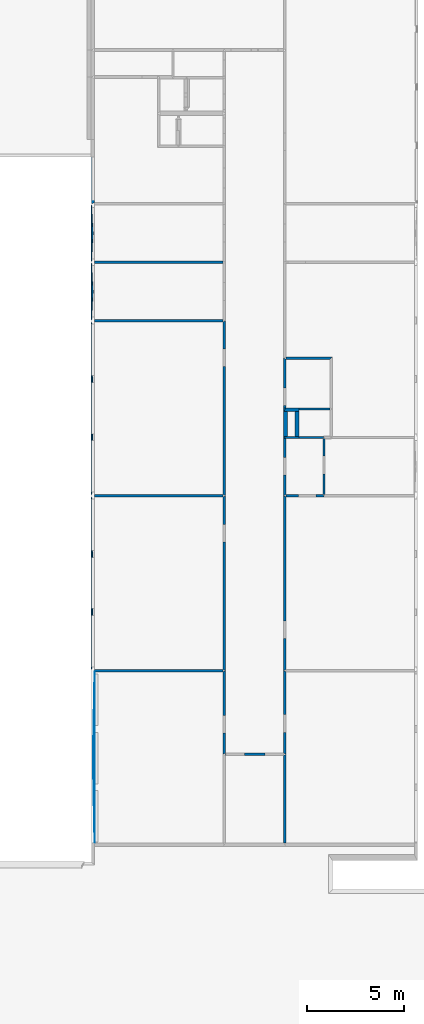
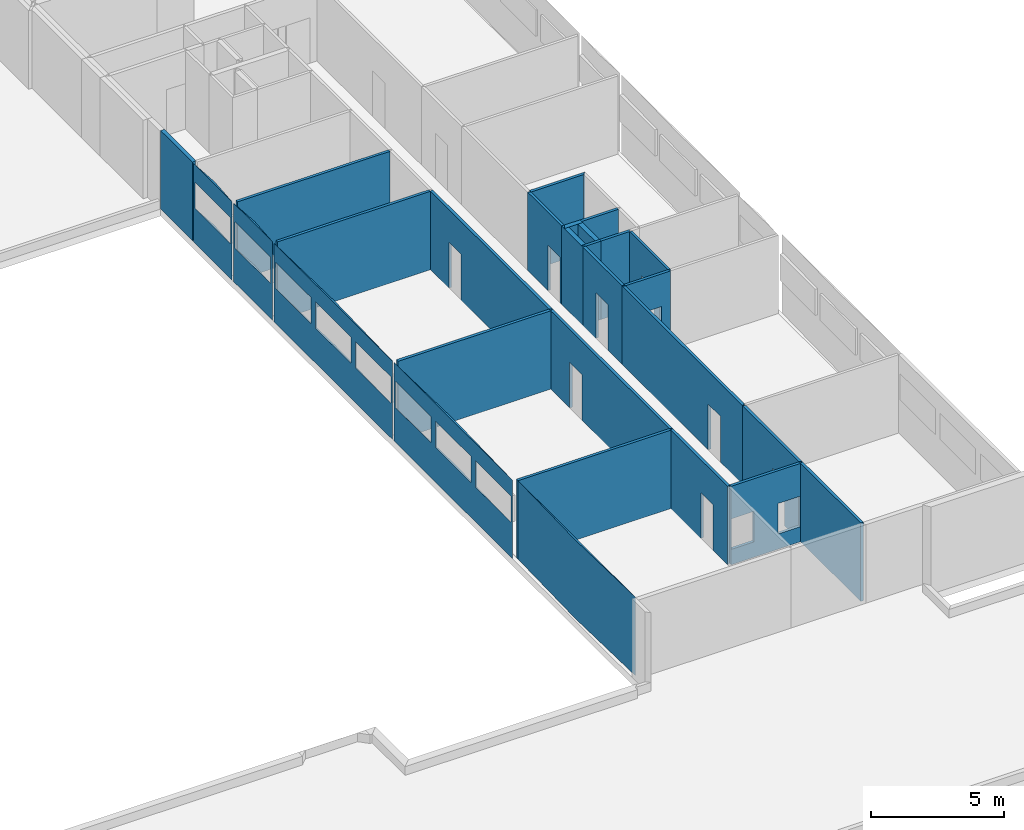
# One storey, part 2 of 72: 28 walls, 23 openings.
"""IFC2X3 building model written with IfcOpenShell, lengths in metres."""

from ifc_helpers import new_model, entity, si_unit, converted_unit, derived_unit, frame, origin_with_axes, place, context, project, spatial, polyline, outline, extrude, material, layer, layer_set, layer_usage, element, save


model = new_model("IFC2X3")

# Units and contexts
context_of_model_1 = context(None, 3, world=origin_with_axes())
context_of_model_2 = context(None, 3, world=origin_with_axes())
context_of_model_3 = context(None, 2, world=origin_with_axes())
context_of_model_4 = context(None, 3, world=origin_with_axes())
ifc_project = project(units=[si_unit("LENGTHUNIT", "METRE"), si_unit("AREAUNIT", "SQUARE_METRE"), si_unit("ELECTRICCURRENTUNIT", "AMPERE"), si_unit("ELECTRICVOLTAGEUNIT", "VOLT"), si_unit("ELECTRICRESISTANCEUNIT", "OHM"), si_unit("POWERUNIT", "WATT"), si_unit("MASSUNIT", "GRAM"), si_unit("SOLIDANGLEUNIT", "STERADIAN"), si_unit("THERMODYNAMICTEMPERATUREUNIT", "KELVIN"), si_unit("PRESSUREUNIT", "PASCAL"), si_unit("LUMINOUSFLUXUNIT", "LUMEN"), si_unit("ILLUMINANCEUNIT", "LUX"), si_unit("FREQUENCYUNIT", "HERTZ"), si_unit("VOLUMEUNIT", "CUBIC_METRE"), si_unit("TIMEUNIT", "SECOND"), derived_unit("VOLUMETRICFLOWRATEUNIT", [(si_unit("TIMEUNIT", "SECOND"), -1), (si_unit("VOLUMEUNIT", "CUBIC_METRE"), 1)]), derived_unit("THERMALTRANSMITTANCEUNIT", [(si_unit("AREAUNIT", "SQUARE_METRE"), -1), (si_unit("THERMODYNAMICTEMPERATUREUNIT", "KELVIN"), -1), (si_unit("POWERUNIT", "WATT"), 1)]), converted_unit("PLANEANGLEUNIT", "DEGREE", entity("IfcPlaneAngleMeasure", 57.29577951308232), si_unit("PLANEANGLEUNIT", "RADIAN"), dimensions=[0, 0, 0, 0, 0, 0, 0])], contexts=[context_of_model_1, context_of_model_2, context_of_model_3, context_of_model_4])

# Site, building, storey
site = spatial("IfcSite", under=ifc_project, CompositionType="ELEMENT")
building_placement = place(None, origin_with_axes())
building = spatial("IfcBuilding", under=site, at=building_placement, Name="200", CompositionType="ELEMENT")
storey_placement = place(building_placement, frame((0.0, 0.0, 15.68000030517578), z_axis=(0.0, 0.0, 1.0), x_axis=(1.0, 0.0, 0.0)))
storey = spatial("IfcBuildingStorey", under=building, at=storey_placement, Name="3.etasje", CompositionType="ELEMENT", Elevation=15.68000030517578)

# Wall, opening
ifc_material_1 = material()
ifc_layer_1 = layer(ifc_material_1, 0.1205999851226807, ventilated=False)
ifc_layer_set_1 = layer_set([ifc_layer_1])
ifc_layer_usage_1 = layer_usage(ifc_layer_set_1, "AXIS2", "POSITIVE", 0.0)
wall_1_placement = place(storey_placement, frame((3.517215490341187, 9.986387252807617, 0.0), z_axis=(0.0, 0.0, 1.0), x_axis=(-4.371138828673793e-08, -1.0, 0.0)))
wall_1 = element("IfcWallStandardCase", 1, at=wall_1_placement, inside=storey, material=ifc_layer_usage_1, context=context_of_model_1, shape_type="SweptSolid", body=[
    extrude(outline(polyline([(0.0, 0.0), (4.258927822113036, 0.0), (4.319228172302245, 0.120598554611206), (0.06029987335205229, 0.120598554611206), (0.0, 0.0)])), frame((0.0, 0.0, 0.0), z_axis=(0.0, 0.0, 1.0), x_axis=(0.999999999999999, 4.37113899295101e-08, 0.0)), (0.0, 0.0, 1.0), 3.6),
])
opening_1_placement = place(wall_1_placement, frame((2.274591917488477, 0.1205986540367805, 0.0), z_axis=(0.0, 0.0, 1.0), x_axis=(1.0, 0.0, 0.0)))
element("IfcOpeningElement", 2, at=opening_1_placement, cuts=wall_1, context=context_of_model_1, shape_type="SweptSolid", body=[
    extrude(outline(polyline([(0.0, 0.0), (2.099999904632568, 0.0), (2.099999904632568, 0.9145503044128417), (0.0, 0.9145503044128417), (0.0, 0.0)])), frame((0.0, 0.0, 0.0), z_axis=(-4.371138992803356e-08, 0.9999999999999991, 0.0), x_axis=(0.0, 0.0, 1.0)), (0.0, -4.371138992803355e-08, -0.9999999999999989), 0.1205985546112061),
])

# Wall
ifc_material_2 = material()
ifc_layer_2 = layer(ifc_material_2, 0.121002197265625, ventilated=False)
ifc_layer_set_2 = layer_set([ifc_layer_2])
ifc_layer_usage_2 = layer_usage(ifc_layer_set_2, "AXIS2", "POSITIVE", 0.0)
wall_2_placement = place(storey_placement, frame((3.517215251922607, 5.60685920715332, 0.0), z_axis=(0.0, 0.0, 1.0), x_axis=(-4.371138828673793e-08, -1.0, 0.0)))
element("IfcWallStandardCase", 3, at=wall_2_placement, inside=storey, material=ifc_layer_usage_2, context=context_of_model_1, shape_type="SweptSolid", body=[
    extrude(outline(polyline([(0.0, 0.0), (4.514073848724365, 2.646977960169689e-23), (4.514073967933655, 0.1205987930297854), (-0.0602998733520514, 0.120598793029785), (0.0, 0.0)])), frame((0.0, 0.0, 0.0), z_axis=(0.0, 0.0, 1.0), x_axis=(0.999999999999999, 4.371138995701829e-08, 0.0)), (0.0, 0.0, 1.0), 3.6),
])

# Wall, opening
wall_3_placement = place(storey_placement, frame((5.547314643859863, 19.08875274658203, 0.0), z_axis=(0.0, 0.0, 1.0), x_axis=(-1.0, -8.742277657347586e-08, 0.0)))
wall_3 = element("IfcWallStandardCase", 4, at=wall_3_placement, inside=storey, material=ifc_layer_usage_2, context=context_of_model_1, shape_type="SweptSolid", body=[
    extrude(outline(polyline([(0.0, 0.0), (1.909500122070313, 2.646977960169689e-23), (1.909500360488891, 0.1205997467041015), (-0.05025053024291978, 0.1205997467041016), (0.0, 0.0)])), frame((0.0, 0.0, 0.0), z_axis=(0.0, 0.0, 1.0), x_axis=(0.9999999999999961, -8.742277995627728e-08, 0.0)), (0.0, 0.0, 1.0), 3.6),
])
opening_2_placement = place(wall_3_placement, frame((0.3617591963341793, 0.1205997150781073, 0.0), z_axis=(0.0, 0.0, 1.0), x_axis=(1.0, 0.0, 0.0)))
element("IfcOpeningElement", 5, at=opening_2_placement, cuts=wall_3, context=context_of_model_1, shape_type="SweptSolid", body=[
    extrude(outline(polyline([(0.0, 0.0), (2.099999904632568, 0.0), (2.099999904632568, 0.9145498275756836), (0.0, 0.9145498275756836), (0.0, 0.0)])), frame((0.0, 0.0, 0.0), z_axis=(8.742278076386086e-08, 0.9999999999999962, 0.0), x_axis=(0.0, 0.0, 1.0)), (0.0, 8.742278076386086e-08, -0.9999999999999962), 0.1205997467041016),
])

wall_4_placement = place(storey_placement, frame((3.517215490341187, 19.0284538269043, 0.0), z_axis=(0.0, 0.0, 1.0), x_axis=(-4.371138828673793e-08, -1.0, 0.0)))
wall_4 = element("IfcWallStandardCase", 6, at=wall_4_placement, inside=storey, material=ifc_layer_usage_2, context=context_of_model_1, shape_type="SweptSolid", body=[
    extrude(outline(polyline([(0.0, 0.0), (9.04206657409668, 0.0), (8.98176670074463, 0.120598793029785), (0.0603008270263667, 0.1205987930297856), (0.0, 0.0)])), frame((0.0, 0.0, 0.0), z_axis=(0.0, 0.0, 1.0), x_axis=(0.999999999999999, 4.371139004139957e-08, 0.0)), (0.0, 0.0, 1.0), 3.6),
])
opening_3_placement = place(wall_4_placement, frame((6.47073840567816, 0.1205990758747557, 0.0), z_axis=(0.0, 0.0, 1.0), x_axis=(1.0, 0.0, 0.0)))
element("IfcOpeningElement", 7, at=opening_3_placement, cuts=wall_4, context=context_of_model_1, shape_type="SweptSolid", body=[
    extrude(outline(polyline([(0.0, 0.0), (2.099999904632568, 0.0), (2.099999904632568, 0.9145488739013684), (0.0, 0.9145488739013684), (0.0, 0.0)])), frame((0.0, 0.0, 0.0), z_axis=(-4.371138983297711e-08, 0.9999999999999991, 0.0), x_axis=(0.0, 0.0, 1.0)), (0.0, -4.371138983297712e-08, -0.9999999999999991), 0.1205987930297852),
])

ifc_material_3 = material()
ifc_layer_3 = layer(ifc_material_3, 0.1010379791259766, ventilated=False)
ifc_layer_set_3 = layer_set([ifc_layer_3])
ifc_layer_usage_3 = layer_usage(ifc_layer_set_3, "AXIS2", "POSITIVE", 0.0)
wall_5_placement = place(storey_placement, frame((5.547314643859863, 21.9686450958252, 0.0), z_axis=(0.0, 0.0, 1.0), x_axis=(-4.371138828673793e-08, -1.0, 0.0)))
wall_5 = element("IfcWallStandardCase", 8, at=wall_5_placement, inside=storey, material=ifc_layer_usage_3, context=context_of_model_1, shape_type="SweptSolid", body=[
    extrude(outline(polyline([(0.0, 0.0), (2.879892349243163, 0.0), (2.879892349243163, 0.1005010604858399), (4.58514314117882e-16, 0.1005010604858399), (0.0, 0.0)])), frame((0.0, 0.0, 0.0), z_axis=(0.0, 0.0, 1.0), x_axis=(0.9999999999999991, 4.371139006134301e-08, 0.0)), (0.0, 0.0, 1.0), 3.6),
])
opening_4_placement = place(wall_5_placement, frame((0.9044990495620375, 0.1005011000227505, 0.0), z_axis=(0.0, 0.0, 1.0), x_axis=(1.0, 0.0, 0.0)))
element("IfcOpeningElement", 9, at=opening_4_placement, cuts=wall_5, context=context_of_model_1, shape_type="SweptSolid", body=[
    extrude(outline(polyline([(0.0, 0.0), (2.099999904632568, 0.0), (2.099999904632568, 0.9145507812500011), (0.0, 0.9145507812500011), (0.0, 0.0)])), frame((0.0, 0.0, 0.0), z_axis=(-4.37113904453007e-08, 0.999999999999999, 0.0), x_axis=(0.0, 0.0, 1.0)), (0.0, -4.371139044530071e-08, -0.9999999999999991), 0.1005010604858398),
])

# Walls
wall_6_placement = place(storey_placement, frame((5.597565174102783, 22.08924674987793, 0.0), z_axis=(0.0, 0.0, 1.0), x_axis=(-1.0, -8.742277657347586e-08, 0.0)))
element("IfcWallStandardCase", 10, at=wall_6_placement, inside=storey, material=ifc_layer_usage_1, context=context_of_model_1, shape_type="SweptSolid", body=[
    extrude(outline(polyline([(0.0, 0.0), (1.287202358245849, 0.0), (1.287202358245849, 0.1206016540527348), (0.05025053024292003, 0.1206016540527352), (0.0, 0.0)])), frame((0.0, 0.0, 0.0), z_axis=(0.0, 0.0, 1.0), x_axis=(0.9999999999999962, -8.742277800063166e-08, 0.0)), (0.0, 0.0, 1.0), 3.6),
])
wall_7_placement = place(storey_placement, frame((4.310362815856934, 22.08924674987793, 0.0), z_axis=(0.0, 0.0, 1.0), x_axis=(-1.0, -8.742277657347586e-08, 0.0)))
element("IfcWallStandardCase", 11, at=wall_7_placement, inside=storey, material=ifc_layer_usage_1, context=context_of_model_1, shape_type="SweptSolid", body=[
    extrude(outline(polyline([(0.0, 0.0), (0.7931473255157474, 0.0), (0.6725482940673831, 0.1206016540527329), (-3.375499185963965e-16, 0.1206016540527348), (0.0, 0.0)])), frame((0.0, 0.0, 0.0), z_axis=(0.0, 0.0, 1.0), x_axis=(0.9999999999999962, -8.742278007312468e-08, 0.0)), (0.0, 0.0, 1.0), 3.6),
])

# Wall, opening
wall_8_placement = place(storey_placement, frame((3.517215490341187, 21.9686450958252, 0.0), z_axis=(0.0, 0.0, 1.0), x_axis=(-4.371138828673793e-08, -1.0, 0.0)))
wall_8 = element("IfcWallStandardCase", 12, at=wall_8_placement, inside=storey, material=ifc_layer_usage_2, context=context_of_model_1, shape_type="SweptSolid", body=[
    extrude(outline(polyline([(0.0, 0.0), (2.940191268920898, 0.0), (2.879892349243162, 0.1205990314483646), (-7.873583759700202e-16, 0.1205990314483644), (0.0, 0.0)])), frame((0.0, 0.0, 0.0), z_axis=(0.0, 0.0, 1.0), x_axis=(0.9999999999999991, 4.371138999271035e-08, 0.0)), (0.0, 0.0, 1.0), 3.6),
])
opening_5_placement = place(wall_8_placement, frame((0.9690589852069635, 0.1205990738072797, 0.0), z_axis=(0.0, 0.0, 1.0), x_axis=(1.0, 0.0, 0.0)))
element("IfcOpeningElement", 13, at=opening_5_placement, cuts=wall_8, context=context_of_model_1, shape_type="SweptSolid", body=[
    extrude(outline(polyline([(0.0, 0.0), (2.099999904632568, 0.0), (2.099999904632568, 0.9145488739013684), (0.0, 0.9145488739013684), (0.0, 0.0)])), frame((0.0, 0.0, 0.0), z_axis=(-4.371139031855992e-08, 0.9999999999999991, 0.0), x_axis=(0.0, 0.0, 1.0)), (0.0, -4.371139031855993e-08, -0.9999999999999991), 0.1205990314483643),
])

# Walls
ifc_material_4 = material()
ifc_layer_4 = layer(ifc_material_4, 0.1238250732421875, ventilated=False)
ifc_layer_set_4 = layer_set([ifc_layer_4])
ifc_layer_usage_4 = layer_usage(ifc_layer_set_4, "AXIS2", "POSITIVE", 0.0)
wall_9_placement = place(storey_placement, frame((3.637814521789551, 26.06524467468262, 0.0), z_axis=(0.0, 0.0, 1.0), x_axis=(1.0, 0.0, 0.0)))
element("IfcWallStandardCase", 14, at=wall_9_placement, inside=storey, material=ifc_layer_usage_4, context=context_of_model_1, shape_type="SweptSolid", body=[
    extrude(outline(polyline([(0.0, 0.0), (2.276000022888184, 0.0), (2.40000057220459, 0.1240005493164063), (2.384185791015625e-07, 0.1240005493164063), (0.0, 0.0)])), origin_with_axes(), (0.0, 0.0, 1.0), 3.6),
])
wall_10_placement = place(storey_placement, frame((5.913814544677734, 23.56538772583008, 0.0), z_axis=(0.0, 0.0, 1.0), x_axis=(-1.0, -8.742277657347586e-08, 0.0)))
element("IfcWallStandardCase", 15, at=wall_10_placement, inside=storey, material=ifc_layer_usage_4, context=context_of_model_1, shape_type="SweptSolid", body=[
    extrude(outline(polyline([(0.0, 0.0), (1.603451728820801, 0.0), (1.603451728820801, 0.1239986419677739), (6.409244731384706e-16, 0.1239986419677739), (0.0, 0.0)])), frame((0.0, 0.0, 0.0), z_axis=(0.0, 0.0, 1.0), x_axis=(0.9999999999999962, -8.742277832506278e-08, 0.0)), (0.0, 0.0, 1.0), 3.6),
])
ifc_material_5 = material()
ifc_layer_5 = layer(ifc_material_5, 0.2000000029802322, ventilated=False)
ifc_layer_set_5 = layer_set([ifc_layer_5])
ifc_layer_usage_5 = layer_usage(ifc_layer_set_5, "AXIS2", "POSITIVE", 0.0)
wall_11_placement = place(storey_placement, frame((4.110363006591797, 23.56538772583008, 0.0), z_axis=(0.0, 0.0, 1.0), x_axis=(-4.371138828673793e-08, -1.0, 0.0)))
element("IfcWallStandardCase", 16, at=wall_11_placement, inside=storey, material=ifc_layer_usage_5, context=context_of_model_1, shape_type="SweptSolid", body=[
    extrude(outline(polyline([(0.0, 0.0), (1.596742630004881, 0.0), (1.476140975952147, 0.1999998092651371), (0.123998641967774, 0.1999998092651363), (0.0, 0.0)])), frame((0.0, 0.0, 0.0), z_axis=(0.0, 0.0, 1.0), x_axis=(0.999999999999999, 4.371138968720196e-08, 0.0)), (0.0, 0.0, 1.0), 3.6),
])
wall_12_placement = place(storey_placement, frame((3.517215490341187, 23.36538696289063, 0.0), z_axis=(0.0, 0.0, 1.0), x_axis=(1.0, 0.0, 0.0)))
element("IfcWallStandardCase", 17, at=wall_12_placement, inside=storey, material=ifc_layer_usage_5, context=context_of_model_1, shape_type="SweptSolid", body=[
    extrude(outline(polyline([(0.0, 0.0), (0.7931473255157471, 0.0), (0.7931473255157471, 0.2000007629394531), (0.1205990314483643, 0.2000007629394531), (0.0, 0.0)])), origin_with_axes(), (0.0, 0.0, 1.0), 3.6),
])

# Wall, opening
wall_13_placement = place(storey_placement, frame((3.517215490341187, 26.12724494934082, 0.0), z_axis=(0.0, 0.0, 1.0), x_axis=(-4.371138828673793e-08, -1.0, 0.0)))
wall_13 = element("IfcWallStandardCase", 18, at=wall_13_placement, inside=storey, material=ifc_layer_usage_2, context=context_of_model_1, shape_type="SweptSolid", body=[
    extrude(outline(polyline([(0.0, 0.0), (2.561857223510744, 0.0), (2.561857223510744, 0.1205990314483644), (0.0620002746582024, 0.1205990314483645), (0.0, 0.0)])), frame((0.0, 0.0, 0.0), z_axis=(0.0, 0.0, 1.0), x_axis=(0.9999999999999991, 4.371139002667359e-08, 0.0)), (0.0, 0.0, 1.0), 3.6),
])
opening_6_placement = place(wall_13_placement, frame((1.534318918678643, 0.1205990985155774, 0.0), z_axis=(0.0, 0.0, 1.0), x_axis=(1.0, 0.0, 0.0)))
element("IfcOpeningElement", 19, at=opening_6_placement, cuts=wall_13, context=context_of_model_1, shape_type="SweptSolid", body=[
    extrude(outline(polyline([(0.0, 0.0), (2.099999904632568, 0.0), (2.099999904632568, 0.9145488739013684), (0.0, 0.9145488739013684), (0.0, 0.0)])), frame((0.0, 0.0, 0.0), z_axis=(-4.371138983297711e-08, 0.9999999999999991, 0.0), x_axis=(0.0, 0.0, 1.0)), (0.0, -4.371138983297712e-08, -0.9999999999999991), 0.1205990314483643),
])

ifc_material_6 = material(Name="Layer-YV3 15 cm")
ifc_layer_6 = layer(ifc_material_6, 0.1500000059604645, ventilated=False)
ifc_layer_set_6 = layer_set([ifc_layer_6])
ifc_layer_usage_6 = layer_usage(ifc_layer_set_6, "AXIS2", "POSITIVE", 0.0)
wall_14_placement = place(storey_placement, frame((-6.411707401275635, 36.50985336303711, 0.0), z_axis=(0.0, 0.0, 1.0), x_axis=(-4.371138828673793e-08, -1.0, 0.0)))
wall_14 = element("IfcWallStandardCase", 20, at=wall_14_placement, inside=storey, material=ifc_layer_usage_6, Name="YV3 15 cm", context=context_of_model_1, shape_type="SweptSolid", body=[
    extrude(outline(polyline([(0.0, 0.0), (2.411388397216799, -1.323488980084844e-23), (2.348575592041015, 0.1658253669738764), (-2.311125446795934e-15, 0.1658253669738771), (0.0, 0.0)])), frame((0.0, 0.0, 0.0), z_axis=(0.0, 0.0, 1.0), x_axis=(0.9999999999999991, 4.371139006932474e-08, 0.0)), (0.0, 0.0, 1.0), 3.6),
])
opening_7_placement = place(wall_14_placement, frame((-7.24845961030951e-09, 0.165825366973877, 1.6), z_axis=(0.0, 0.0, 1.0), x_axis=(1.0, 0.0, 0.0)))
element("IfcOpeningElement", 21, at=opening_7_placement, cuts=wall_14, context=context_of_model_1, shape_type="SweptSolid", body=[
    extrude(outline(polyline([(0.0, 0.0), (1.200000047683716, 0.0), (1.200000047683716, 2.232543945312503), (0.0, 2.232543945312503), (0.0, 0.0)])), frame((0.0, 0.0, 0.0), z_axis=(-4.371138971372868e-08, 0.999999999999999, 0.0), x_axis=(0.0, 0.0, 1.0)), (0.0, -4.371138971372869e-08, -0.9999999999999992), 0.1500000059604645),
])

# Wall
wall_15_placement = place(storey_placement, frame((-6.245882511138916, 31.02163124084473, 0.0), z_axis=(0.0, 0.0, 1.0), x_axis=(1.0, 0.0, 0.0)))
element("IfcWallStandardCase", 22, at=wall_15_placement, inside=storey, material=ifc_layer_usage_2, context=context_of_model_1, shape_type="SweptSolid", body=[
    extrude(outline(polyline([(0.0, 0.0), (6.630110055208206, 0.0), (6.630110114812851, 0.1205997467041016), (0.0, 0.1205997467041016), (0.0, 0.0)])), origin_with_axes(), (0.0, 0.0, 1.0), 3.6),
])

# Wall, opening
ifc_material_7 = material(Name="Layer-YV3 15 cm")
ifc_layer_7 = layer(ifc_material_7, 0.166, ventilated=False)
ifc_layer_set_7 = layer_set([ifc_layer_7])
ifc_layer_usage_7 = layer_usage(ifc_layer_set_7, "AXIS2", "POSITIVE", 0.0)
wall_16_placement = place(storey_placement, frame((-6.245882511138916, 34.0356559753418, 0.0), z_axis=(0.0, 0.0, 1.0), x_axis=(-4.371138828673793e-08, -1.0, 0.0)))
wall_16 = element("IfcWallStandardCase", 23, at=wall_16_placement, inside=storey, material=ifc_layer_usage_7, Name="YV3 15 cm", context=context_of_model_1, shape_type="SweptSolid", body=[
    extrude(outline(polyline([(0.0, 0.0), (2.893424987792967, 0.0), (1.842933853220385e-15, 0.1658248901367189), (2.89342498779297, 0.1658248901367189), (0.0, 0.0)])), frame((0.0, 0.0, 0.0), z_axis=(0.0, 0.0, -1.0), x_axis=(0.9999999999999991, 4.371139003992351e-08, 0.0)), (0.0, 0.0, -1.0), 3.6),
])
opening_8_placement = place(wall_16_placement, frame((0.1215286254882813, 5.312185358263832e-09, 1.6), z_axis=(0.0, 0.0, 1.0), x_axis=(1.0, 0.0, 0.0)))
element("IfcOpeningElement", 24, at=opening_8_placement, cuts=wall_16, context=context_of_model_1, shape_type="SweptSolid", body=[
    extrude(outline(polyline([(0.0, 0.0), (1.200000047683716, 0.0), (1.200000047683716, 2.65822410583496), (0.0, 2.65822410583496), (0.0, 0.0)])), frame((0.0, 0.0, 0.0), z_axis=(-4.371138973223426e-08, 0.999999999999999, 0.0), x_axis=(0.0, 0.0, 1.0)), (0.0, -4.371138973223427e-08, -0.9999999999999992), 0.1658248954122305),
])

# Wall
wall_17_placement = place(storey_placement, frame((-6.245882511138916, 27.99350929260254, 0.0), z_axis=(0.0, 0.0, 1.0), x_axis=(1.0, 0.0, 0.0)))
element("IfcWallStandardCase", 25, at=wall_17_placement, inside=storey, material=ifc_layer_usage_2, context=context_of_model_1, shape_type="SweptSolid", body=[
    extrude(outline(polyline([(0.0, 0.0), (6.630109965801239, 0.0), (6.630110055208206, 0.1205997467041016), (0.0, 0.1205997467041016), (0.0, 0.0)])), origin_with_axes(), (0.0, 0.0, 1.0), 3.6),
])

# Wall, opening
wall_18_placement = place(storey_placement, frame((-6.245882511138916, 31.02163124084473, 0.0), z_axis=(0.0, 0.0, 1.0), x_axis=(-4.371138828673793e-08, -1.0, 0.0)))
wall_18 = element("IfcWallStandardCase", 26, at=wall_18_placement, inside=storey, material=ifc_layer_usage_7, Name="YV3 15 cm", context=context_of_model_1, shape_type="SweptSolid", body=[
    extrude(outline(polyline([(0.0, 0.0), (2.907522201538085, 0.0), (1.814570470253735e-15, 0.1658248901367189), (2.907522201538087, 0.1658248901367189), (0.0, 0.0)])), frame((0.0, 0.0, 0.0), z_axis=(0.0, 0.0, -1.0), x_axis=(0.9999999999999991, 4.371139021096769e-08, 0.0)), (0.0, 0.0, -1.0), 3.6),
])
opening_9_placement = place(wall_18_placement, frame((0.1187896728515625, 5.192461571823515e-09, 1.6), z_axis=(0.0, 0.0, 1.0), x_axis=(1.0, 0.0, 0.0)))
element("IfcOpeningElement", 27, at=opening_9_placement, cuts=wall_18, context=context_of_model_1, shape_type="SweptSolid", body=[
    extrude(outline(polyline([(0.0, 0.0), (1.200000047683716, 0.0), (1.200000047683716, 2.658227920532225), (0.0, 2.658227920532225), (0.0, 0.0)])), frame((0.0, 0.0, 0.0), z_axis=(-4.371138981944425e-08, 0.999999999999999, 0.0), x_axis=(0.0, 0.0, 1.0)), (0.0, -4.371138981944425e-08, -0.9999999999999991), 0.1658248956938541),
])

# Wall
ifc_material_8 = material()
ifc_layer_8 = layer(ifc_material_8, 0.1260013580322266, ventilated=False)
ifc_layer_set_8 = layer_set([ifc_layer_8])
ifc_layer_usage_8 = layer_usage(ifc_layer_set_8, "AXIS2", "POSITIVE", 0.0)
wall_19_placement = place(storey_placement, frame((-6.245882987976074, 18.95598793029785, 0.0), z_axis=(0.0, 0.0, 1.0), x_axis=(1.0, 0.0, 0.0)))
element("IfcWallStandardCase", 28, at=wall_19_placement, inside=storey, material=ifc_layer_usage_8, context=context_of_model_1, shape_type="SweptSolid", body=[
    extrude(outline(polyline([(0.0, 0.0), (6.630110234022141, 0.0), (6.630110442638397, 0.1256256103515625), (4.76837158203125e-07, 0.1256256103515625), (0.0, 0.0)])), origin_with_axes(), (0.0, 0.0, 1.0), 3.6),
])

# Wall, opening
wall_20_placement = place(storey_placement, frame((0.5048271417617798, 19.01880073547363, 0.0), z_axis=(0.0, 0.0, 1.0), x_axis=(-4.371138828673793e-08, 1.0, 0.0)))
wall_20 = element("IfcWallStandardCase", 29, at=wall_20_placement, inside=storey, material=ifc_layer_usage_2, context=context_of_model_1, shape_type="SweptSolid", body=[
    extrude(outline(polyline([(0.0, 0.0), (9.035009384155272, 0.0), (8.974708557128906, 0.1205996870994567), (0.06281280517578186, 0.1205996870994567), (0.0, 0.0)])), frame((0.0, 0.0, 0.0), z_axis=(0.0, 0.0, 1.0), x_axis=(0.999999999999999, -4.37113900053001e-08, 0.0)), (0.0, 0.0, 1.0), 3.6),
])
opening_10_placement = place(wall_20_placement, frame((6.675689702537198, 0.1205993952957807, 0.0), z_axis=(0.0, 0.0, 1.0), x_axis=(1.0, 0.0, 0.0)))
element("IfcOpeningElement", 30, at=opening_10_placement, cuts=wall_20, context=context_of_model_1, shape_type="SweptSolid", body=[
    extrude(outline(polyline([(0.0, 0.0), (2.099999904632568, 0.0), (2.099999904632568, 0.9145488739013684), (0.0, 0.9145488739013684), (0.0, 0.0)])), frame((0.0, 0.0, 0.0), z_axis=(4.371139007576852e-08, 0.9999999999999991, 0.0), x_axis=(0.0, 0.0, 1.0)), (0.0, 4.371139007576853e-08, -0.9999999999999991), 0.1205996870994568),
])

# Wall, openings
wall_21_placement = place(storey_placement, frame((-6.245882511138916, 27.99350929260254, 0.0), z_axis=(0.0, 0.0, 1.0), x_axis=(-4.371138828673793e-08, -1.0, 0.0)))
wall_21 = element("IfcWallStandardCase", 31, at=wall_21_placement, inside=storey, material=ifc_layer_usage_7, Name="YV3 15 cm", context=context_of_model_1, shape_type="SweptSolid", body=[
    extrude(outline(polyline([(0.0, 0.0), (8.911895751953125, 0.0), (1.860061240744129e-15, 0.1658248901367189), (8.911895751953127, 0.1658253669738771), (0.0, 0.0)])), frame((0.0, 0.0, 0.0), z_axis=(0.0, 0.0, -1.0), x_axis=(0.999999999999999, 4.371138993663751e-08, 0.0)), (0.0, 0.0, -1.0), 3.6),
])
opening_11_placement = place(wall_21_placement, frame((6.130245208740227, 2.679615391798507e-07, 1.6), z_axis=(0.0, 0.0, 1.0), x_axis=(1.0, 0.0, 0.0)))
element("IfcOpeningElement", 32, at=opening_11_placement, cuts=wall_21, context=context_of_model_1, shape_type="SweptSolid", body=[
    extrude(outline(polyline([(0.0, 0.0), (1.200000047683716, 0.0), (1.200000047683716, 2.658226013183593), (0.0, 2.658226013183593), (0.0, 0.0)])), frame((0.0, 0.0, 0.0), z_axis=(-4.371138944171479e-08, 0.999999999999999, 0.0), x_axis=(0.0, 0.0, 1.0)), (0.0, -4.37113894417148e-08, -0.9999999999999992), 0.1658248962944884),
])
opening_12_placement = place(wall_21_placement, frame((3.121780395507809, 1.364573600781682e-07, 1.6), z_axis=(0.0, 0.0, 1.0), x_axis=(1.0, 0.0, 0.0)))
element("IfcOpeningElement", 33, at=opening_12_placement, cuts=wall_21, context=context_of_model_1, shape_type="SweptSolid", body=[
    extrude(outline(polyline([(0.0, 0.0), (1.200000047683716, 0.0), (1.200000047683716, 2.65822410583496), (0.0, 2.65822410583496), (0.0, 0.0)])), frame((0.0, 0.0, 0.0), z_axis=(-4.371138973223426e-08, 0.999999999999999, 0.0), x_axis=(0.0, 0.0, 1.0)), (0.0, -4.371138973223427e-08, -0.9999999999999992), 0.1658248962944884),
])
opening_13_placement = place(wall_21_placement, frame((0.11260986328125, 4.922333651791178e-09, 1.6), z_axis=(0.0, 0.0, 1.0), x_axis=(1.0, 0.0, 0.0)))
element("IfcOpeningElement", 34, at=opening_13_placement, cuts=wall_21, context=context_of_model_1, shape_type="SweptSolid", body=[
    extrude(outline(polyline([(0.0, 0.0), (1.200000047683716, 0.0), (1.200000047683716, 2.658226013183593), (0.0, 2.658226013183593), (0.0, 0.0)])), frame((0.0, 0.0, 0.0), z_axis=(-4.371138944171479e-08, 0.999999999999999, 0.0), x_axis=(0.0, 0.0, 1.0)), (0.0, -4.37113894417148e-08, -0.9999999999999992), 0.1658248962944884),
])

# Wall
wall_22_placement = place(storey_placement, frame((-6.245882987976074, 9.926087379455566, 0.0), z_axis=(0.0, 0.0, 1.0), x_axis=(1.0, 0.0, 0.0)))
element("IfcWallStandardCase", 35, at=wall_22_placement, inside=storey, material=ifc_layer_usage_2, context=context_of_model_1, shape_type="SweptSolid", body=[
    extrude(outline(polyline([(0.0, 0.0), (6.630110025405884, 0.0), (6.630110234022141, 0.1205997467041016), (0.0, 0.1205997467041016), (0.0, 0.0)])), origin_with_axes(), (0.0, 0.0, 1.0), 3.6),
])

# Wall, opening
wall_23_placement = place(storey_placement, frame((0.5048271417617798, 9.986387252807617, 0.0), z_axis=(0.0, 0.0, 1.0), x_axis=(-4.371138828673793e-08, 1.0, 0.0)))
wall_23 = element("IfcWallStandardCase", 36, at=wall_23_placement, inside=storey, material=ifc_layer_usage_2, context=context_of_model_1, shape_type="SweptSolid", body=[
    extrude(outline(polyline([(0.0, 0.0), (9.032413482666017, 0.0), (8.96960067749024, 0.1205998957157134), (0.06029987335205116, 0.1205998957157135), (0.0, 0.0)])), frame((0.0, 0.0, 0.0), z_axis=(0.0, 0.0, 1.0), x_axis=(0.999999999999999, -4.371138999380103e-08, 0.0)), (0.0, 0.0, 1.0), 3.6),
])
opening_14_placement = place(wall_23_placement, frame((6.636894231345803, 0.1205996056078414, 0.0), z_axis=(0.0, 0.0, 1.0), x_axis=(1.0, 0.0, 0.0)))
element("IfcOpeningElement", 37, at=opening_14_placement, cuts=wall_23, context=context_of_model_1, shape_type="SweptSolid", body=[
    extrude(outline(polyline([(0.0, 0.0), (2.099999904632568, 0.0), (2.099999904632568, 0.9145507812500011), (0.0, 0.9145507812500011), (0.0, 0.0)])), frame((0.0, 0.0, 0.0), z_axis=(4.371139008111436e-08, 0.999999999999999, 0.0), x_axis=(0.0, 0.0, 1.0)), (0.0, 4.371139008111437e-08, -0.9999999999999991), 0.1205998957157135),
])

# Wall, openings
wall_24_placement = place(storey_placement, frame((-6.245882987976074, 18.95598793029785, 0.0), z_axis=(0.0, 0.0, 1.0), x_axis=(-4.371138828673793e-08, -1.0, 0.0)))
wall_24 = element("IfcWallStandardCase", 38, at=wall_24_placement, inside=storey, material=ifc_layer_usage_7, Name="YV3 15 cm", context=context_of_model_1, shape_type="SweptSolid", body=[
    extrude(outline(polyline([(0.0, 0.0), (8.909300804138187, 0.0), (1.852653394989908e-15, 0.1658248901367189), (8.909300804138187, 0.1658253669738771), (0.0, 0.0)])), frame((0.0, 0.0, 0.0), z_axis=(0.0, 0.0, -1.0), x_axis=(0.999999999999999, 4.371138998131021e-08, 0.0)), (0.0, 0.0, -1.0), 3.6),
])
opening_15_placement = place(wall_24_placement, frame((6.126585006713862, 2.678015462720396e-07, 1.6), z_axis=(0.0, 0.0, 1.0), x_axis=(1.0, 0.0, 0.0)))
element("IfcOpeningElement", 39, at=opening_15_placement, cuts=wall_24, context=context_of_model_1, shape_type="SweptSolid", body=[
    extrude(outline(polyline([(0.0, 0.0), (1.200000047683716, 0.0), (1.200000047683716, 2.658226013183594), (0.0, 2.658226013183594), (0.0, 0.0)])), frame((0.0, 0.0, 0.0), z_axis=(-4.371138977583926e-08, 0.999999999999999, 0.0), x_axis=(0.0, 0.0, 1.0)), (0.0, -4.371138977583926e-08, -0.9999999999999991), 0.165824896447597),
])
opening_16_placement = place(wall_24_placement, frame((3.113012313842772, 1.360740951028561e-07, 1.6), z_axis=(0.0, 0.0, 1.0), x_axis=(1.0, 0.0, 0.0)))
element("IfcOpeningElement", 40, at=opening_16_placement, cuts=wall_24, context=context_of_model_1, shape_type="SweptSolid", body=[
    extrude(outline(polyline([(0.0, 0.0), (1.200000047683716, 0.0), (1.200000047683716, 2.658226013183593), (0.0, 2.658226013183593), (0.0, 0.0)])), frame((0.0, 0.0, 0.0), z_axis=(-4.371138977583929e-08, 0.999999999999999, 0.0), x_axis=(0.0, 0.0, 1.0)), (0.0, -4.371138977583929e-08, -0.9999999999999992), 0.165824896447597),
])
opening_17_placement = place(wall_24_placement, frame((0.1040096282958984, 4.546405030225742e-09, 1.6), z_axis=(0.0, 0.0, 1.0), x_axis=(1.0, 0.0, 0.0)))
element("IfcOpeningElement", 41, at=opening_17_placement, cuts=wall_24, context=context_of_model_1, shape_type="SweptSolid", body=[
    extrude(outline(polyline([(0.0, 0.0), (1.200000047683716, 0.0), (1.200000047683716, 2.658227920532229), (0.0, 2.658227920532229), (0.0, 0.0)])), frame((0.0, 0.0, 0.0), z_axis=(-4.371138981944419e-08, 0.999999999999999, 0.0), x_axis=(0.0, 0.0, 1.0)), (0.0, -4.371138981944419e-08, -0.9999999999999992), 0.165824896447597),
])

# Wall, opening
wall_25_placement = place(storey_placement, frame((0.5048271417617798, 5.72745943069458, 0.0), z_axis=(0.0, 0.0, 1.0), x_axis=(-4.371138828673793e-08, 1.0, 0.0)))
wall_25 = element("IfcWallStandardCase", 42, at=wall_25_placement, inside=storey, material=ifc_layer_usage_1, context=context_of_model_1, shape_type="SweptSolid", body=[
    extrude(outline(polyline([(0.0, 0.0), (4.258927822113034, 0.0), (4.198627948760984, 0.1206001043319702), (-0.06030035018920896, 0.1206001043319701), (0.0, 0.0)])), frame((0.0, 0.0, 0.0), z_axis=(0.0, 0.0, 1.0), x_axis=(0.999999999999999, -4.371139000771452e-08, 0.0)), (0.0, 0.0, 1.0), 3.6),
])
opening_18_placement = place(wall_25_placement, frame((1.037980084922475, 0.120600058960418, 0.0), z_axis=(0.0, 0.0, 1.0), x_axis=(1.0, 0.0, 0.0)))
element("IfcOpeningElement", 43, at=opening_18_placement, cuts=wall_25, context=context_of_model_1, shape_type="SweptSolid", body=[
    extrude(outline(polyline([(0.0, 0.0), (2.099999904632568, 0.0), (2.099999904632568, 0.9145493507385254), (0.0, 0.9145493507385254), (0.0, 0.0)])), frame((0.0, 0.0, 0.0), z_axis=(4.371139004675611e-08, 0.999999999999999, 0.0), x_axis=(0.0, 0.0, 1.0)), (0.0, 4.371139004675611e-08, -0.9999999999999991), 0.1211369037628174),
])

# Wall, openings
wall_26_placement = place(storey_placement, frame((-6.411708831787109, 1.092785835266113, 0.0), z_axis=(0.0, 0.0, 1.0), x_axis=(7.549790126404332e-08, 1.0, 0.0)))
wall_26 = element("IfcWallStandardCase", 44, at=wall_26_placement, inside=storey, material=ifc_layer_usage_7, Name="YV3 15 cm", context=context_of_model_1, shape_type="SweptSolid", body=[
    extrude(outline(polyline([(0.0, 0.0), (8.833301544189466, 2.646977960169689e-23), (-3.486762977541331e-07, 0.1658258438110543), (8.83330155314101, 0.1658253669738763), (0.0, 0.0)])), frame((0.0, 0.0, 0.0), z_axis=(0.0, 0.0, -1.0), x_axis=(0.9999999999999998, 2.151614012418453e-08, 0.0)), (0.0, 0.0, -1.0), 3.6),
])
opening_19_placement = place(wall_26_placement, frame((2.695896161201136, -0.1658256402765383, 1.600000023841858), z_axis=(0.0, 0.0, 1.0), x_axis=(1.0, 0.0, 0.0)))
element("IfcOpeningElement", 45, at=opening_19_placement, cuts=wall_26, context=context_of_model_1, shape_type="SweptSolid", body=[
    extrude(outline(polyline([(0.0, 0.0), (2.657999992370606, 0.0), (2.657999992370606, 1.399999976158142), (0.0, 1.399999976158142), (0.0, 0.0)])), frame((0.0, 0.0, 0.0), z_axis=(-7.549789892782065e-08, 0.9999999999999971, 0.0), x_axis=(-0.9999999999999971, -7.549789892782065e-08, 0.0)), (7.549789892782067e-08, 0.0, -0.9999999999999973), 0.1658253727539389),
])
opening_20_placement = place(wall_26_placement, frame((5.709469807746538, -0.1658254127580578, 1.600000023841858), z_axis=(0.0, 0.0, 1.0), x_axis=(1.0, 0.0, 0.0)))
element("IfcOpeningElement", 46, at=opening_20_placement, cuts=wall_26, context=context_of_model_1, shape_type="SweptSolid", body=[
    extrude(outline(polyline([(0.0, 0.0), (2.657999992370606, 0.0), (2.657999992370606, 1.399999976158142), (0.0, 1.399999976158142), (0.0, 0.0)])), frame((0.0, 0.0, 0.0), z_axis=(-7.549789892782065e-08, 0.9999999999999971, 0.0), x_axis=(-0.9999999999999971, -7.549789892782065e-08, 0.0)), (7.549789892782067e-08, 0.0, -0.9999999999999973), 0.1658253727539389),
])
opening_21_placement = place(wall_26_placement, frame((8.723042500617622, -0.1658251852396493, 1.6), z_axis=(0.0, 0.0, 1.0), x_axis=(1.0, 0.0, 0.0)))
element("IfcOpeningElement", 47, at=opening_21_placement, cuts=wall_26, context=context_of_model_1, shape_type="SweptSolid", body=[
    extrude(outline(polyline([(0.0, 0.0), (2.658224582672118, 0.0), (2.658224582672118, 1.200000047683716), (0.0, 1.200000047683716), (0.0, 0.0)])), frame((0.0, 0.0, 0.0), z_axis=(-7.54978989723341e-08, 0.9999999999999972, 0.0), x_axis=(-0.9999999999999971, -7.54978989723341e-08, 0.0)), (7.54978989723341e-08, 0.0, -0.9999999999999971), 0.1658253727539389),
])

wall_27_placement = place(storey_placement, frame((0.505363941192627, 5.60685920715332, 0.0), z_axis=(0.0, 0.0, 1.0), x_axis=(1.0, 0.0, 0.0)))
wall_27 = element("IfcWallStandardCase", 48, at=wall_27_placement, inside=storey, material=ifc_layer_usage_2, context=context_of_model_1, shape_type="SweptSolid", body=[
    extrude(outline(polyline([(0.0, 0.0), (3.011851310729981, 0.0), (3.01185154914856, 0.1206002235412598), (-0.000536799430847168, 0.1206002235412598), (0.0, 0.0)])), origin_with_axes(), (0.0, 0.0, 1.0), 3.6),
])
opening_22_placement = place(wall_27_placement, frame((0.02033352851867676, 0.1206002235412598, 0.7), z_axis=(0.0, 0.0, 1.0), x_axis=(1.0, 0.0, 0.0)))
element("IfcOpeningElement", 49, at=opening_22_placement, cuts=wall_27, context=context_of_model_1, shape_type="SweptSolid", body=[
    extrude(outline(polyline([(0.0, 0.0), (1.399999976158142, 0.0), (1.399999976158142, 0.9647998809814453), (-2.220446049250313e-16, 0.9647998809814453), (-2.220446049250313e-16, 0.0)])), frame((0.0, 0.0, 2.220446049250313e-16), z_axis=(0.0, 1.0, 0.0), x_axis=(0.0, 0.0, 1.0)), (0.0, 0.0, -1.0), 0.1206002235412598),
])
opening_23_placement = place(wall_27_placement, frame((2.036649942398071, 0.1206002235412598, 0.7), z_axis=(0.0, 0.0, 1.0), x_axis=(1.0, 0.0, 0.0)))
element("IfcOpeningElement", 50, at=opening_23_placement, cuts=wall_27, context=context_of_model_1, shape_type="SweptSolid", body=[
    extrude(outline(polyline([(0.0, 0.0), (1.399999976158142, 0.0), (1.399999976158142, 0.9547498226165771), (-2.220446049250313e-16, 0.9547498226165771), (-2.220446049250313e-16, 0.0)])), frame((0.0, 0.0, 2.220446049250313e-16), z_axis=(0.0, 1.0, 0.0), x_axis=(0.0, 0.0, 1.0)), (0.0, 0.0, -1.0), 0.1206002235412598),
])

# Wall
wall_28_placement = place(storey_placement, frame((3.717215538024902, 21.9686450958252, 0.0), z_axis=(0.0, 0.0, 1.0), x_axis=(-4.371138828673793e-08, 1.0, 0.0)))
element("IfcWallStandardCase", 51, at=wall_28_placement, inside=storey, material=ifc_layer_usage_5, context=context_of_model_1, shape_type="SweptSolid", body=[
    extrude(outline(polyline([(0.0, 0.0), (1.596742630004881, 0.0), (1.596742630004881, 0.200000047683716), (-2.884104999189653e-16, 0.200000047683716), (0.0, 0.0)])), frame((0.0, 0.0, 0.0), z_axis=(0.0, 0.0, 1.0), x_axis=(0.999999999999999, -4.371138996532393e-08, 0.0)), (0.0, 0.0, 1.0), 3.6),
])

save(model, "model.ifc")
